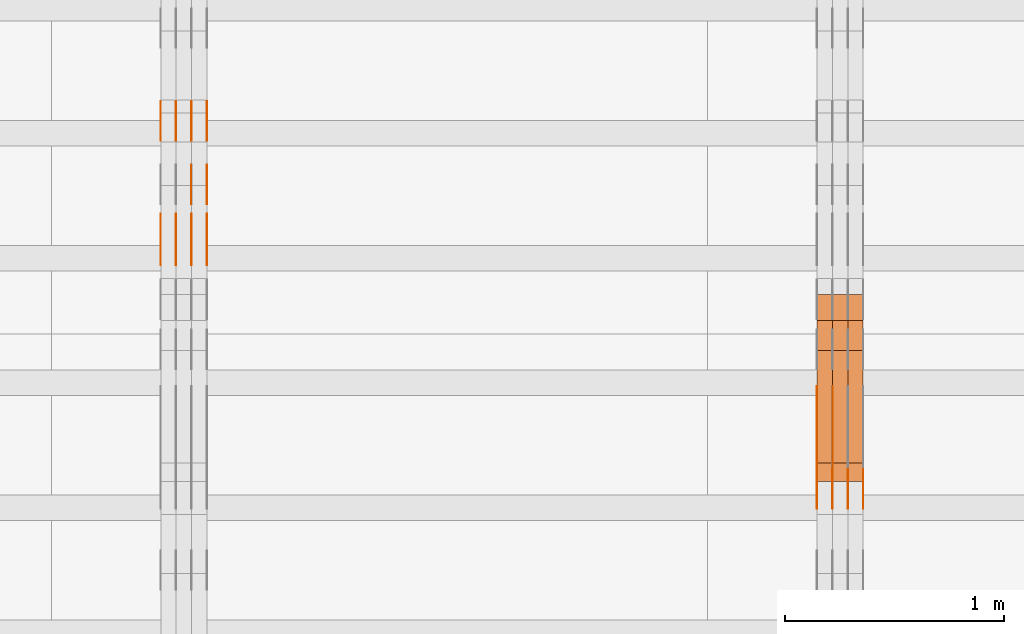
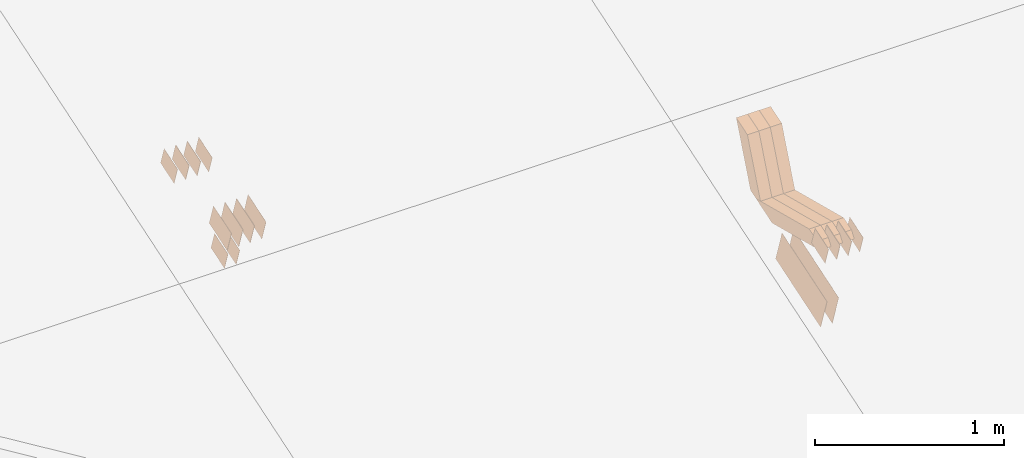
# One storey, part 70 of 385: 28 proxies.
"""IFC2X3 building model written with IfcOpenShell, lengths in millimetres."""

from ifc_helpers import new_model, entity, si_unit, converted_unit, derived_unit, direction, frame, origin, place, context, subcontext, project, spatial, polyline, outline, extrude, source, transform, mapped, material, type_object, type_shapes, element, save


model = new_model("IFC2X3")

# Units and contexts
model_context = context("Model", 3, precision=0.01, world=origin(), true_north=direction((6.12303176911189e-17, 1.0)))
body_context = subcontext(model_context, "Body", "Model", "MODEL_VIEW")
ifc_project = project(units=[si_unit("LENGTHUNIT", "METRE", prefix="MILLI"), si_unit("AREAUNIT", "SQUARE_METRE"), si_unit("VOLUMEUNIT", "CUBIC_METRE"), converted_unit("PLANEANGLEUNIT", "DEGREE", entity("IfcRatioMeasure", 0.0174532925199433), si_unit("PLANEANGLEUNIT", "RADIAN"), dimensions=[0, 0, 0, 0, 0, 0, 0]), si_unit("MASSUNIT", "GRAM", prefix="KILO"), derived_unit("MASSDENSITYUNIT", [(si_unit("MASSUNIT", "GRAM", prefix="KILO"), 1), (si_unit("LENGTHUNIT", "METRE"), -3)]), si_unit("TIMEUNIT", "SECOND"), si_unit("FREQUENCYUNIT", "HERTZ"), si_unit("THERMODYNAMICTEMPERATUREUNIT", "DEGREE_CELSIUS"), derived_unit("THERMALTRANSMITTANCEUNIT", [(si_unit("MASSUNIT", "GRAM", prefix="KILO"), 1), (si_unit("THERMODYNAMICTEMPERATUREUNIT", "KELVIN"), -1), (si_unit("TIMEUNIT", "SECOND"), -3)]), derived_unit("VOLUMETRICFLOWRATEUNIT", [(si_unit("LENGTHUNIT", "METRE"), 3), (si_unit("TIMEUNIT", "SECOND"), -1)]), si_unit("ELECTRICCURRENTUNIT", "AMPERE"), si_unit("ELECTRICVOLTAGEUNIT", "VOLT"), si_unit("POWERUNIT", "WATT"), si_unit("FORCEUNIT", "NEWTON", prefix="KILO"), si_unit("ILLUMINANCEUNIT", "LUX"), si_unit("LUMINOUSFLUXUNIT", "LUMEN"), si_unit("LUMINOUSINTENSITYUNIT", "CANDELA"), derived_unit("USERDEFINED", [(si_unit("MASSUNIT", "GRAM", prefix="KILO"), -1), (si_unit("LENGTHUNIT", "METRE"), -2), (si_unit("TIMEUNIT", "SECOND"), 3), (si_unit("LUMINOUSFLUXUNIT", "LUMEN"), 1)]), derived_unit("LINEARVELOCITYUNIT", [(si_unit("LENGTHUNIT", "METRE"), 1), (si_unit("TIMEUNIT", "SECOND"), -1)]), si_unit("PRESSUREUNIT", "PASCAL"), derived_unit("USERDEFINED", [(si_unit("LENGTHUNIT", "METRE"), -2), (si_unit("MASSUNIT", "GRAM", prefix="KILO"), 1), (si_unit("TIMEUNIT", "SECOND"), -2)])], contexts=[model_context])

# Site, building, storey
site_placement = place(None, origin())
site = spatial("IfcSite", under=ifc_project, at=site_placement, CompositionType="ELEMENT")
building_placement = place(site_placement, origin())
building = spatial("IfcBuilding", under=site, at=building_placement, CompositionType="ELEMENT")
storey_placement = place(building_placement, origin())
storey = spatial("IfcBuildingStorey", under=building, at=storey_placement, Name="Default", CompositionType="ELEMENT", Elevation=0.0)

# Proxies
ifc_material_1 = material(Name="IfcSurfaceStyle #211648")
building_element_proxy_type_1 = type_object("IfcBuildingElementProxyType", PredefinedType="NOTDEFINED", material=ifc_material_1)
shared_shape_1 = source(origin(), body_context, "Body", "SweptSolid", [
    extrude(outline(polyline([(-249.999749056184, -108.000229288163), (249.999396050782, -108.000229288163), (249.999749056184, 108.000229288163), (-249.999396050782, 108.000229288163), (-249.999749056184, -108.000229288163)])), frame((249.999841104007, 108.000229288163, 0.0), z_axis=(0.0, 0.0, 1.0), x_axis=(-1.0, 0.0, 0.0)), (0.0, 0.0, 1.0), 1.29999999999997),
])
type_shapes(building_element_proxy_type_1, [shared_shape_1])
proxy_1_placement = place(building_placement, frame((15246.3, 7917.13457673635, 1720.66532252899), z_axis=(-1.0, 0.0, 0.0), x_axis=(0.0, 0.951056516295124, 0.309016994375039)))
element("IfcBuildingElementProxy", 1, at=proxy_1_placement, inside=storey, type_object=building_element_proxy_type_1, material=ifc_material_1, context=body_context, shape_type="MappedRepresentation", body=[
    mapped(shared_shape_1, transform((0.0, 0.0, 0.0), scale=1.0)),
])
ifc_material_2 = material(Name="IfcSurfaceStyle #211591")
building_element_proxy_type_2 = type_object("IfcBuildingElementProxyType", PredefinedType="NOTDEFINED", material=ifc_material_2)
shared_shape_2 = source(origin(), body_context, "Body", "SweptSolid", [
    extrude(outline(polyline([(-249.999749056184, -108.000229288163), (249.999396050782, -108.000229288163), (249.999749056184, 108.000229288163), (-249.999396050782, 108.000229288163), (-249.999749056184, -108.000229288163)])), frame((249.999841104007, 108.000229288163, 0.0), z_axis=(0.0, 0.0, 1.0), x_axis=(-1.0, 0.0, 0.0)), (0.0, 0.0, 1.0), 1.29999999999997),
])
type_shapes(building_element_proxy_type_2, [shared_shape_2])
proxy_2_placement = place(building_placement, frame((15175.0, 7917.13457673635, 1720.66532252899), z_axis=(-1.0, 0.0, 0.0), x_axis=(0.0, 0.951056516295124, 0.309016994375039)))
element("IfcBuildingElementProxy", 2, at=proxy_2_placement, inside=storey, type_object=building_element_proxy_type_2, material=ifc_material_2, context=body_context, shape_type="MappedRepresentation", body=[
    mapped(shared_shape_2, transform((0.0, 0.0, 0.0), scale=1.0)),
])
ifc_material_3 = material(Name="IfcSurfaceStyle #198196")
building_element_proxy_type_3 = type_object("IfcBuildingElementProxyType", PredefinedType="NOTDEFINED", material=ifc_material_3)
shared_shape_3 = source(origin(), body_context, "Body", "SweptSolid", [
    extrude(outline(polyline([(-74.9998754286253, -60.0000016373506), (74.9998605591091, -60.0000016373506), (74.9998754286234, 60.0000016373506), (-74.9998605591072, 60.0000016373506), (-74.9998754286253, -60.0000016373506)])), frame((75.0007355357002, 60.0002637031812, 0.0), z_axis=(0.0, 0.0, 1.0), x_axis=(-1.0, 0.0, 0.0)), (0.0, 0.0, 1.0), 1.3),
])
type_shapes(building_element_proxy_type_3, [shared_shape_3])
proxy_3_placement = place(building_placement, frame((15386.3, 7899.79204652808, 2069.58672486412), z_axis=(-1.0, 0.0, 0.0), x_axis=(0.0, 0.951056516295154, 0.309016994374948)))
element("IfcBuildingElementProxy", 3, at=proxy_3_placement, inside=storey, type_object=building_element_proxy_type_3, material=ifc_material_3, context=body_context, shape_type="MappedRepresentation", body=[
    mapped(shared_shape_3, transform((0.0, 0.0, 0.0), scale=1.0)),
])
ifc_material_4 = material(Name="IfcSurfaceStyle #198139")
building_element_proxy_type_4 = type_object("IfcBuildingElementProxyType", PredefinedType="NOTDEFINED", material=ifc_material_4)
shared_shape_4 = source(origin(), body_context, "Body", "SweptSolid", [
    extrude(outline(polyline([(-74.9998754286253, -60.0000016373506), (74.9998605591091, -60.0000016373506), (74.9998754286234, 60.0000016373506), (-74.9998605591072, 60.0000016373506), (-74.9998754286253, -60.0000016373506)])), frame((75.0007355357002, 60.0002637031812, 0.0), z_axis=(0.0, 0.0, 1.0), x_axis=(-1.0, 0.0, 0.0)), (0.0, 0.0, 1.0), 1.3),
])
type_shapes(building_element_proxy_type_4, [shared_shape_4])
proxy_4_placement = place(building_placement, frame((15315.0, 7899.79204652808, 2069.58672486412), z_axis=(-1.0, 0.0, 0.0), x_axis=(0.0, 0.951056516295154, 0.309016994374948)))
element("IfcBuildingElementProxy", 4, at=proxy_4_placement, inside=storey, type_object=building_element_proxy_type_4, material=ifc_material_4, context=body_context, shape_type="MappedRepresentation", body=[
    mapped(shared_shape_4, transform((0.0, 0.0, 0.0), scale=1.0)),
])
ifc_material_5 = material(Name="IfcSurfaceStyle #198082")
building_element_proxy_type_5 = type_object("IfcBuildingElementProxyType", PredefinedType="NOTDEFINED", material=ifc_material_5)
shared_shape_5 = source(origin(), body_context, "Body", "SweptSolid", [
    extrude(outline(polyline([(-74.9998754286253, -60.0000016373506), (74.9998605591091, -60.0000016373506), (74.9998754286234, 60.0000016373506), (-74.9998605591072, 60.0000016373506), (-74.9998754286253, -60.0000016373506)])), frame((75.0007355357002, 60.0002637031812, 0.0), z_axis=(0.0, 0.0, 1.0), x_axis=(-1.0, 0.0, 0.0)), (0.0, 0.0, 1.0), 1.3),
])
type_shapes(building_element_proxy_type_5, [shared_shape_5])
proxy_5_placement = place(building_placement, frame((15316.3, 7899.79204652808, 2069.58672486412), z_axis=(-1.0, 0.0, 0.0), x_axis=(0.0, 0.951056516295154, 0.309016994374948)))
element("IfcBuildingElementProxy", 5, at=proxy_5_placement, inside=storey, type_object=building_element_proxy_type_5, material=ifc_material_5, context=body_context, shape_type="MappedRepresentation", body=[
    mapped(shared_shape_5, transform((0.0, 0.0, 0.0), scale=1.0)),
])
ifc_material_6 = material(Name="IfcSurfaceStyle #198025")
building_element_proxy_type_6 = type_object("IfcBuildingElementProxyType", PredefinedType="NOTDEFINED", material=ifc_material_6)
shared_shape_6 = source(origin(), body_context, "Body", "SweptSolid", [
    extrude(outline(polyline([(-74.9998754286253, -60.0000016373506), (74.9998605591091, -60.0000016373506), (74.9998754286234, 60.0000016373506), (-74.9998605591072, 60.0000016373506), (-74.9998754286253, -60.0000016373506)])), frame((75.0007355357002, 60.0002637031812, 0.0), z_axis=(0.0, 0.0, 1.0), x_axis=(-1.0, 0.0, 0.0)), (0.0, 0.0, 1.0), 1.29999999999999),
])
type_shapes(building_element_proxy_type_6, [shared_shape_6])
proxy_6_placement = place(building_placement, frame((15245.0, 7899.79204652808, 2069.58672486412), z_axis=(-1.0, 0.0, 0.0), x_axis=(0.0, 0.951056516295154, 0.309016994374948)))
element("IfcBuildingElementProxy", 6, at=proxy_6_placement, inside=storey, type_object=building_element_proxy_type_6, material=ifc_material_6, context=body_context, shape_type="MappedRepresentation", body=[
    mapped(shared_shape_6, transform((0.0, 0.0, 0.0), scale=1.0)),
])
ifc_material_7 = material(Name="IfcSurfaceStyle #197968")
building_element_proxy_type_7 = type_object("IfcBuildingElementProxyType", PredefinedType="NOTDEFINED", material=ifc_material_7)
shared_shape_7 = source(origin(), body_context, "Body", "SweptSolid", [
    extrude(outline(polyline([(-74.9998754286253, -60.0000016373506), (74.9998605591091, -60.0000016373506), (74.9998754286234, 60.0000016373506), (-74.9998605591072, 60.0000016373506), (-74.9998754286253, -60.0000016373506)])), frame((75.0007355357002, 60.0002637031812, 0.0), z_axis=(0.0, 0.0, 1.0), x_axis=(-1.0, 0.0, 0.0)), (0.0, 0.0, 1.0), 1.29999999999999),
])
type_shapes(building_element_proxy_type_7, [shared_shape_7])
proxy_7_placement = place(building_placement, frame((15246.3, 7899.79204652808, 2069.58672486412), z_axis=(-1.0, 0.0, 0.0), x_axis=(0.0, 0.951056516295154, 0.309016994374948)))
element("IfcBuildingElementProxy", 7, at=proxy_7_placement, inside=storey, type_object=building_element_proxy_type_7, material=ifc_material_7, context=body_context, shape_type="MappedRepresentation", body=[
    mapped(shared_shape_7, transform((0.0, 0.0, 0.0), scale=1.0)),
])
ifc_material_8 = material(Name="IfcSurfaceStyle #197911")
building_element_proxy_type_8 = type_object("IfcBuildingElementProxyType", PredefinedType="NOTDEFINED", material=ifc_material_8)
shared_shape_8 = source(origin(), body_context, "Body", "SweptSolid", [
    extrude(outline(polyline([(-74.9998754286253, -60.0000016373506), (74.9998605591091, -60.0000016373506), (74.9998754286234, 60.0000016373506), (-74.9998605591072, 60.0000016373506), (-74.9998754286253, -60.0000016373506)])), frame((75.0007355357002, 60.0002637031812, 0.0), z_axis=(0.0, 0.0, 1.0), x_axis=(-1.0, 0.0, 0.0)), (0.0, 0.0, 1.0), 1.29999999999999),
])
type_shapes(building_element_proxy_type_8, [shared_shape_8])
proxy_8_placement = place(building_placement, frame((15175.0, 7899.79204652808, 2069.58672486412), z_axis=(-1.0, 0.0, 0.0), x_axis=(0.0, 0.951056516295154, 0.309016994374948)))
element("IfcBuildingElementProxy", 8, at=proxy_8_placement, inside=storey, type_object=building_element_proxy_type_8, material=ifc_material_8, context=body_context, shape_type="MappedRepresentation", body=[
    mapped(shared_shape_8, transform((0.0, 0.0, 0.0), scale=1.0)),
])
ifc_material_9 = material(Name="IfcSurfaceStyle #185812")
building_element_proxy_type_9 = type_object("IfcBuildingElementProxyType", Name="T1-W45 185810", PredefinedType="NOTDEFINED", material=ifc_material_9)
shared_shape_9 = source(origin(), body_context, "Body", "SweptSolid", [
    extrude(outline(polyline([(-275.953018340717, -47.500197738425), (128.971267956636, -47.5001977384251), (168.669977842085, -0.000132525443043008), (174.867371111815, 47.5002640011466), (-196.55559856982, 47.5002640011466), (-275.953018340717, -47.500197738425)])), frame((174.867371111815, 47.5002640011466, 0.0), z_axis=(0.0, 0.0, 1.0), x_axis=(-1.0, 0.0, 0.0)), (0.0, 0.0, 1.0), 70.0),
])
type_shapes(building_element_proxy_type_9, [shared_shape_9])
proxy_9_placement = place(building_placement, frame((15385.0, 8621.494140625, 1941.33422851563), z_axis=(-1.0, 0.0, 0.0), x_axis=(0.0, 0.372787901688292, 0.927916580493549)))
element("IfcBuildingElementProxy", 9, at=proxy_9_placement, inside=storey, type_object=building_element_proxy_type_9, material=ifc_material_9, Name="T1-W45", context=body_context, shape_type="MappedRepresentation", body=[
    mapped(shared_shape_9, transform((0.0, 0.0, 0.0), scale=1.0)),
])
ifc_material_10 = material(Name="IfcSurfaceStyle #185746")
building_element_proxy_type_10 = type_object("IfcBuildingElementProxyType", Name="T1-W45 185744", PredefinedType="NOTDEFINED", material=ifc_material_10)
shared_shape_10 = source(origin(), body_context, "Body", "SweptSolid", [
    extrude(outline(polyline([(-275.953018340717, -47.500197738425), (128.971267956636, -47.5001977384251), (168.669977842085, -0.000132525443043008), (174.867371111815, 47.5002640011466), (-196.55559856982, 47.5002640011466), (-275.953018340717, -47.500197738425)])), frame((174.867371111815, 47.5002640011466, 0.0), z_axis=(0.0, 0.0, 1.0), x_axis=(-1.0, 0.0, 0.0)), (0.0, 0.0, 1.0), 70.0),
])
type_shapes(building_element_proxy_type_10, [shared_shape_10])
proxy_10_placement = place(building_placement, frame((15315.0, 8621.494140625, 1941.33422851563), z_axis=(-1.0, 0.0, 0.0), x_axis=(0.0, 0.372787901688292, 0.927916580493549)))
element("IfcBuildingElementProxy", 10, at=proxy_10_placement, inside=storey, type_object=building_element_proxy_type_10, material=ifc_material_10, Name="T1-W45", context=body_context, shape_type="MappedRepresentation", body=[
    mapped(shared_shape_10, transform((0.0, 0.0, 0.0), scale=1.0)),
])
ifc_material_11 = material(Name="IfcSurfaceStyle #185680")
building_element_proxy_type_11 = type_object("IfcBuildingElementProxyType", Name="T1-W45 185678", PredefinedType="NOTDEFINED", material=ifc_material_11)
shared_shape_11 = source(origin(), body_context, "Body", "SweptSolid", [
    extrude(outline(polyline([(-275.953018340717, -47.500197738425), (128.971267956636, -47.5001977384251), (168.669977842085, -0.000132525443043008), (174.867371111815, 47.5002640011466), (-196.55559856982, 47.5002640011466), (-275.953018340717, -47.500197738425)])), frame((174.867371111815, 47.5002640011466, 0.0), z_axis=(0.0, 0.0, 1.0), x_axis=(-1.0, 0.0, 0.0)), (0.0, 0.0, 1.0), 70.0),
])
type_shapes(building_element_proxy_type_11, [shared_shape_11])
proxy_11_placement = place(building_placement, frame((15245.0, 8621.494140625, 1941.33422851563), z_axis=(-1.0, 0.0, 0.0), x_axis=(0.0, 0.372787901688292, 0.927916580493549)))
element("IfcBuildingElementProxy", 11, at=proxy_11_placement, inside=storey, type_object=building_element_proxy_type_11, material=ifc_material_11, Name="T1-W45", context=body_context, shape_type="MappedRepresentation", body=[
    mapped(shared_shape_11, transform((0.0, 0.0, 0.0), scale=1.0)),
])
ifc_material_12 = material(Name="IfcSurfaceStyle #185416")
building_element_proxy_type_12 = type_object("IfcBuildingElementProxyType", Name="T1-W11 185414", PredefinedType="NOTDEFINED", material=ifc_material_12)
shared_shape_12 = source(origin(), body_context, "Body", "SweptSolid", [
    extrude(outline(polyline([(-261.366417792209, -47.5000378467523), (260.949520182121, -47.5000378467523), (242.928845159301, -7.41559889341215e-06), (168.237407166939, 47.5000415545517), (-410.749354716152, 47.5000415545517), (-261.366417792209, -47.5000378467523)])), frame((260.949520182121, 47.5000415545517, 0.0), z_axis=(0.0, 0.0, 1.0), x_axis=(-1.0, 0.0, 0.0)), (0.0, 0.0, 1.0), 70.0),
])
type_shapes(building_element_proxy_type_12, [shared_shape_12])
proxy_12_placement = place(building_placement, frame((15385.0, 8017.44318793234, 2097.03832883996), z_axis=(-1.0, 0.0, 0.0), x_axis=(0.0, 0.968347201599873, -0.249607085543851)))
element("IfcBuildingElementProxy", 12, at=proxy_12_placement, inside=storey, type_object=building_element_proxy_type_12, material=ifc_material_12, Name="T1-W11", context=body_context, shape_type="MappedRepresentation", body=[
    mapped(shared_shape_12, transform((0.0, 0.0, 0.0), scale=1.0)),
])
ifc_material_13 = material(Name="IfcSurfaceStyle #185350")
building_element_proxy_type_13 = type_object("IfcBuildingElementProxyType", Name="T1-W11 185348", PredefinedType="NOTDEFINED", material=ifc_material_13)
shared_shape_13 = source(origin(), body_context, "Body", "SweptSolid", [
    extrude(outline(polyline([(-261.366417792209, -47.5000378467523), (260.949520182121, -47.5000378467523), (242.928845159301, -7.41559889341215e-06), (168.237407166939, 47.5000415545517), (-410.749354716152, 47.5000415545517), (-261.366417792209, -47.5000378467523)])), frame((260.949520182121, 47.5000415545517, 0.0), z_axis=(0.0, 0.0, 1.0), x_axis=(-1.0, 0.0, 0.0)), (0.0, 0.0, 1.0), 70.0),
])
type_shapes(building_element_proxy_type_13, [shared_shape_13])
proxy_13_placement = place(building_placement, frame((15315.0, 8017.44318793234, 2097.03832883996), z_axis=(-1.0, 0.0, 0.0), x_axis=(0.0, 0.968347201599873, -0.249607085543851)))
element("IfcBuildingElementProxy", 13, at=proxy_13_placement, inside=storey, type_object=building_element_proxy_type_13, material=ifc_material_13, Name="T1-W11", context=body_context, shape_type="MappedRepresentation", body=[
    mapped(shared_shape_13, transform((0.0, 0.0, 0.0), scale=1.0)),
])
ifc_material_14 = material(Name="IfcSurfaceStyle #185284")
building_element_proxy_type_14 = type_object("IfcBuildingElementProxyType", Name="T1-W11 185282", PredefinedType="NOTDEFINED", material=ifc_material_14)
shared_shape_14 = source(origin(), body_context, "Body", "SweptSolid", [
    extrude(outline(polyline([(-261.366417792209, -47.5000378467523), (260.949520182121, -47.5000378467523), (242.928845159301, -7.41559889341215e-06), (168.237407166939, 47.5000415545517), (-410.749354716152, 47.5000415545517), (-261.366417792209, -47.5000378467523)])), frame((260.949520182121, 47.5000415545517, 0.0), z_axis=(0.0, 0.0, 1.0), x_axis=(-1.0, 0.0, 0.0)), (0.0, 0.0, 1.0), 70.0),
])
type_shapes(building_element_proxy_type_14, [shared_shape_14])
proxy_14_placement = place(building_placement, frame((15245.0, 8017.44318793234, 2097.03832883996), z_axis=(-1.0, 0.0, 0.0), x_axis=(0.0, 0.968347201599873, -0.249607085543851)))
element("IfcBuildingElementProxy", 14, at=proxy_14_placement, inside=storey, type_object=building_element_proxy_type_14, material=ifc_material_14, Name="T1-W11", context=body_context, shape_type="MappedRepresentation", body=[
    mapped(shared_shape_14, transform((0.0, 0.0, 0.0), scale=1.0)),
])
ifc_material_15 = material(Name="IfcSurfaceStyle #177102")
building_element_proxy_type_15 = type_object("IfcBuildingElementProxyType", PredefinedType="NOTDEFINED", material=ifc_material_15)
shared_shape_15 = source(origin(), body_context, "Body", "SweptSolid", [
    extrude(outline(polyline([(-99.999644645517, -72.0000317581407), (100.000028485991, -72.0000317581407), (99.999644645517, 72.0000317581407), (-100.000028485991, 72.0000317581407), (-99.999644645517, -72.0000317581407)])), frame((100.000028485991, 72.0000317581407, 0.0), z_axis=(0.0, 0.0, 1.0), x_axis=(-1.0, 0.0, 0.0)), (0.0, 0.0, 1.0), 1.3),
])
type_shapes(building_element_proxy_type_15, [shared_shape_15])
proxy_15_placement = place(building_placement, frame((12386.3, 9012.6304394324, 2546.30522609783), z_axis=(-1.0, 0.0, 0.0), x_axis=(0.0, 0.951056516295154, 0.309016994374948)))
element("IfcBuildingElementProxy", 15, at=proxy_15_placement, inside=storey, type_object=building_element_proxy_type_15, material=ifc_material_15, context=body_context, shape_type="MappedRepresentation", body=[
    mapped(shared_shape_15, transform((0.0, 0.0, 0.0), scale=1.0)),
])
ifc_material_16 = material(Name="IfcSurfaceStyle #177045")
building_element_proxy_type_16 = type_object("IfcBuildingElementProxyType", PredefinedType="NOTDEFINED", material=ifc_material_16)
shared_shape_16 = source(origin(), body_context, "Body", "SweptSolid", [
    extrude(outline(polyline([(-99.999644645517, -72.0000317581407), (100.000028485991, -72.0000317581407), (99.999644645517, 72.0000317581407), (-100.000028485991, 72.0000317581407), (-99.999644645517, -72.0000317581407)])), frame((100.000028485991, 72.0000317581407, 0.0), z_axis=(0.0, 0.0, 1.0), x_axis=(-1.0, 0.0, 0.0)), (0.0, 0.0, 1.0), 1.3),
])
type_shapes(building_element_proxy_type_16, [shared_shape_16])
proxy_16_placement = place(building_placement, frame((12315.0, 9012.6304394324, 2546.30522609783), z_axis=(-1.0, 0.0, 0.0), x_axis=(0.0, 0.951056516295154, 0.309016994374948)))
element("IfcBuildingElementProxy", 16, at=proxy_16_placement, inside=storey, type_object=building_element_proxy_type_16, material=ifc_material_16, context=body_context, shape_type="MappedRepresentation", body=[
    mapped(shared_shape_16, transform((0.0, 0.0, 0.0), scale=1.0)),
])
ifc_material_17 = material(Name="IfcSurfaceStyle #176988")
building_element_proxy_type_17 = type_object("IfcBuildingElementProxyType", PredefinedType="NOTDEFINED", material=ifc_material_17)
shared_shape_17 = source(origin(), body_context, "Body", "SweptSolid", [
    extrude(outline(polyline([(-99.999644645517, -72.0000317581407), (100.000028485991, -72.0000317581407), (99.999644645517, 72.0000317581407), (-100.000028485991, 72.0000317581407), (-99.999644645517, -72.0000317581407)])), frame((100.000028485991, 72.0000317581407, 0.0), z_axis=(0.0, 0.0, 1.0), x_axis=(-1.0, 0.0, 0.0)), (0.0, 0.0, 1.0), 1.3),
])
type_shapes(building_element_proxy_type_17, [shared_shape_17])
proxy_17_placement = place(building_placement, frame((12316.3, 9012.6304394324, 2546.30522609783), z_axis=(-1.0, 0.0, 0.0), x_axis=(0.0, 0.951056516295154, 0.309016994374948)))
element("IfcBuildingElementProxy", 17, at=proxy_17_placement, inside=storey, type_object=building_element_proxy_type_17, material=ifc_material_17, context=body_context, shape_type="MappedRepresentation", body=[
    mapped(shared_shape_17, transform((0.0, 0.0, 0.0), scale=1.0)),
])
ifc_material_18 = material(Name="IfcSurfaceStyle #176931")
building_element_proxy_type_18 = type_object("IfcBuildingElementProxyType", PredefinedType="NOTDEFINED", material=ifc_material_18)
shared_shape_18 = source(origin(), body_context, "Body", "SweptSolid", [
    extrude(outline(polyline([(-99.999644645517, -72.0000317581407), (100.000028485991, -72.0000317581407), (99.999644645517, 72.0000317581407), (-100.000028485991, 72.0000317581407), (-99.999644645517, -72.0000317581407)])), frame((100.000028485991, 72.0000317581407, 0.0), z_axis=(0.0, 0.0, 1.0), x_axis=(-1.0, 0.0, 0.0)), (0.0, 0.0, 1.0), 1.29999999999998),
])
type_shapes(building_element_proxy_type_18, [shared_shape_18])
proxy_18_placement = place(building_placement, frame((12245.0, 9012.6304394324, 2546.30522609783), z_axis=(-1.0, 0.0, 0.0), x_axis=(0.0, 0.951056516295154, 0.309016994374948)))
element("IfcBuildingElementProxy", 18, at=proxy_18_placement, inside=storey, type_object=building_element_proxy_type_18, material=ifc_material_18, context=body_context, shape_type="MappedRepresentation", body=[
    mapped(shared_shape_18, transform((0.0, 0.0, 0.0), scale=1.0)),
])
ifc_material_19 = material(Name="IfcSurfaceStyle #176874")
building_element_proxy_type_19 = type_object("IfcBuildingElementProxyType", PredefinedType="NOTDEFINED", material=ifc_material_19)
shared_shape_19 = source(origin(), body_context, "Body", "SweptSolid", [
    extrude(outline(polyline([(-99.999644645517, -72.0000317581407), (100.000028485991, -72.0000317581407), (99.999644645517, 72.0000317581407), (-100.000028485991, 72.0000317581407), (-99.999644645517, -72.0000317581407)])), frame((100.000028485991, 72.0000317581407, 0.0), z_axis=(0.0, 0.0, 1.0), x_axis=(-1.0, 0.0, 0.0)), (0.0, 0.0, 1.0), 1.29999999999998),
])
type_shapes(building_element_proxy_type_19, [shared_shape_19])
proxy_19_placement = place(building_placement, frame((12246.3, 9012.6304394324, 2546.30522609783), z_axis=(-1.0, 0.0, 0.0), x_axis=(0.0, 0.951056516295154, 0.309016994374948)))
element("IfcBuildingElementProxy", 19, at=proxy_19_placement, inside=storey, type_object=building_element_proxy_type_19, material=ifc_material_19, context=body_context, shape_type="MappedRepresentation", body=[
    mapped(shared_shape_19, transform((0.0, 0.0, 0.0), scale=1.0)),
])
ifc_material_20 = material(Name="IfcSurfaceStyle #176817")
building_element_proxy_type_20 = type_object("IfcBuildingElementProxyType", PredefinedType="NOTDEFINED", material=ifc_material_20)
shared_shape_20 = source(origin(), body_context, "Body", "SweptSolid", [
    extrude(outline(polyline([(-99.999644645517, -72.0000317581407), (100.000028485991, -72.0000317581407), (99.999644645517, 72.0000317581407), (-100.000028485991, 72.0000317581407), (-99.999644645517, -72.0000317581407)])), frame((100.000028485991, 72.0000317581407, 0.0), z_axis=(0.0, 0.0, 1.0), x_axis=(-1.0, 0.0, 0.0)), (0.0, 0.0, 1.0), 1.29999999999999),
])
type_shapes(building_element_proxy_type_20, [shared_shape_20])
proxy_20_placement = place(building_placement, frame((12175.0, 9012.6304394324, 2546.30522609783), z_axis=(-1.0, 0.0, 0.0), x_axis=(0.0, 0.951056516295154, 0.309016994374948)))
element("IfcBuildingElementProxy", 20, at=proxy_20_placement, inside=storey, type_object=building_element_proxy_type_20, material=ifc_material_20, context=body_context, shape_type="MappedRepresentation", body=[
    mapped(shared_shape_20, transform((0.0, 0.0, 0.0), scale=1.0)),
])
ifc_material_21 = material(Name="IfcSurfaceStyle #176760")
building_element_proxy_type_21 = type_object("IfcBuildingElementProxyType", PredefinedType="NOTDEFINED", material=ifc_material_21)
shared_shape_21 = source(origin(), body_context, "Body", "SweptSolid", [
    extrude(outline(polyline([(-74.9998754286207, -60.0000016373506), (74.9998605591063, -60.0000016373506), (74.9998754286244, 60.0000016373506), (-74.9998605591099, 60.0000016373506), (-74.9998754286207, -60.0000016373506)])), frame((74.9998754286244, 60.0000016373506, 0.0), z_axis=(0.0, 0.0, 1.0), x_axis=(-1.0, 0.0, 0.0)), (0.0, 0.0, 1.0), 1.3),
])
type_shapes(building_element_proxy_type_21, [shared_shape_21])
proxy_21_placement = place(building_placement, frame((12386.3, 9580.89841427132, 2615.81135078741), z_axis=(-1.0, 0.0, 0.0), x_axis=(0.0, 0.951056516295154, 0.309016994374948)))
element("IfcBuildingElementProxy", 21, at=proxy_21_placement, inside=storey, type_object=building_element_proxy_type_21, material=ifc_material_21, context=body_context, shape_type="MappedRepresentation", body=[
    mapped(shared_shape_21, transform((0.0, 0.0, 0.0), scale=1.0)),
])
ifc_material_22 = material(Name="IfcSurfaceStyle #176703")
building_element_proxy_type_22 = type_object("IfcBuildingElementProxyType", PredefinedType="NOTDEFINED", material=ifc_material_22)
shared_shape_22 = source(origin(), body_context, "Body", "SweptSolid", [
    extrude(outline(polyline([(-74.9998754286207, -60.0000016373506), (74.9998605591063, -60.0000016373506), (74.9998754286244, 60.0000016373506), (-74.9998605591099, 60.0000016373506), (-74.9998754286207, -60.0000016373506)])), frame((74.9998754286244, 60.0000016373506, 0.0), z_axis=(0.0, 0.0, 1.0), x_axis=(-1.0, 0.0, 0.0)), (0.0, 0.0, 1.0), 1.3),
])
type_shapes(building_element_proxy_type_22, [shared_shape_22])
proxy_22_placement = place(building_placement, frame((12315.0, 9580.89841427132, 2615.81135078741), z_axis=(-1.0, 0.0, 0.0), x_axis=(0.0, 0.951056516295154, 0.309016994374948)))
element("IfcBuildingElementProxy", 22, at=proxy_22_placement, inside=storey, type_object=building_element_proxy_type_22, material=ifc_material_22, context=body_context, shape_type="MappedRepresentation", body=[
    mapped(shared_shape_22, transform((0.0, 0.0, 0.0), scale=1.0)),
])
ifc_material_23 = material(Name="IfcSurfaceStyle #176646")
building_element_proxy_type_23 = type_object("IfcBuildingElementProxyType", PredefinedType="NOTDEFINED", material=ifc_material_23)
shared_shape_23 = source(origin(), body_context, "Body", "SweptSolid", [
    extrude(outline(polyline([(-74.9998754286207, -60.0000016373506), (74.9998605591063, -60.0000016373506), (74.9998754286244, 60.0000016373506), (-74.9998605591099, 60.0000016373506), (-74.9998754286207, -60.0000016373506)])), frame((74.9998754286244, 60.0000016373506, 0.0), z_axis=(0.0, 0.0, 1.0), x_axis=(-1.0, 0.0, 0.0)), (0.0, 0.0, 1.0), 1.3),
])
type_shapes(building_element_proxy_type_23, [shared_shape_23])
proxy_23_placement = place(building_placement, frame((12316.3, 9580.89841427132, 2615.81135078741), z_axis=(-1.0, 0.0, 0.0), x_axis=(0.0, 0.951056516295154, 0.309016994374948)))
element("IfcBuildingElementProxy", 23, at=proxy_23_placement, inside=storey, type_object=building_element_proxy_type_23, material=ifc_material_23, context=body_context, shape_type="MappedRepresentation", body=[
    mapped(shared_shape_23, transform((0.0, 0.0, 0.0), scale=1.0)),
])
ifc_material_24 = material(Name="IfcSurfaceStyle #176589")
building_element_proxy_type_24 = type_object("IfcBuildingElementProxyType", PredefinedType="NOTDEFINED", material=ifc_material_24)
shared_shape_24 = source(origin(), body_context, "Body", "SweptSolid", [
    extrude(outline(polyline([(-74.9998754286207, -60.0000016373506), (74.9998605591063, -60.0000016373506), (74.9998754286244, 60.0000016373506), (-74.9998605591099, 60.0000016373506), (-74.9998754286207, -60.0000016373506)])), frame((74.9998754286244, 60.0000016373506, 0.0), z_axis=(0.0, 0.0, 1.0), x_axis=(-1.0, 0.0, 0.0)), (0.0, 0.0, 1.0), 1.29999999999999),
])
type_shapes(building_element_proxy_type_24, [shared_shape_24])
proxy_24_placement = place(building_placement, frame((12245.0, 9580.89841427132, 2615.81135078741), z_axis=(-1.0, 0.0, 0.0), x_axis=(0.0, 0.951056516295154, 0.309016994374948)))
element("IfcBuildingElementProxy", 24, at=proxy_24_placement, inside=storey, type_object=building_element_proxy_type_24, material=ifc_material_24, context=body_context, shape_type="MappedRepresentation", body=[
    mapped(shared_shape_24, transform((0.0, 0.0, 0.0), scale=1.0)),
])
ifc_material_25 = material(Name="IfcSurfaceStyle #176532")
building_element_proxy_type_25 = type_object("IfcBuildingElementProxyType", PredefinedType="NOTDEFINED", material=ifc_material_25)
shared_shape_25 = source(origin(), body_context, "Body", "SweptSolid", [
    extrude(outline(polyline([(-74.9998754286207, -60.0000016373506), (74.9998605591063, -60.0000016373506), (74.9998754286244, 60.0000016373506), (-74.9998605591099, 60.0000016373506), (-74.9998754286207, -60.0000016373506)])), frame((74.9998754286244, 60.0000016373506, 0.0), z_axis=(0.0, 0.0, 1.0), x_axis=(-1.0, 0.0, 0.0)), (0.0, 0.0, 1.0), 1.29999999999999),
])
type_shapes(building_element_proxy_type_25, [shared_shape_25])
proxy_25_placement = place(building_placement, frame((12246.3, 9580.89841427132, 2615.81135078741), z_axis=(-1.0, 0.0, 0.0), x_axis=(0.0, 0.951056516295154, 0.309016994374948)))
element("IfcBuildingElementProxy", 25, at=proxy_25_placement, inside=storey, type_object=building_element_proxy_type_25, material=ifc_material_25, context=body_context, shape_type="MappedRepresentation", body=[
    mapped(shared_shape_25, transform((0.0, 0.0, 0.0), scale=1.0)),
])
ifc_material_26 = material(Name="IfcSurfaceStyle #176475")
building_element_proxy_type_26 = type_object("IfcBuildingElementProxyType", PredefinedType="NOTDEFINED", material=ifc_material_26)
shared_shape_26 = source(origin(), body_context, "Body", "SweptSolid", [
    extrude(outline(polyline([(-74.9998754286207, -60.0000016373506), (74.9998605591063, -60.0000016373506), (74.9998754286244, 60.0000016373506), (-74.9998605591099, 60.0000016373506), (-74.9998754286207, -60.0000016373506)])), frame((74.9998754286244, 60.0000016373506, 0.0), z_axis=(0.0, 0.0, 1.0), x_axis=(-1.0, 0.0, 0.0)), (0.0, 0.0, 1.0), 1.29999999999999),
])
type_shapes(building_element_proxy_type_26, [shared_shape_26])
proxy_26_placement = place(building_placement, frame((12175.0, 9580.89841427132, 2615.81135078741), z_axis=(-1.0, 0.0, 0.0), x_axis=(0.0, 0.951056516295154, 0.309016994374948)))
element("IfcBuildingElementProxy", 26, at=proxy_26_placement, inside=storey, type_object=building_element_proxy_type_26, material=ifc_material_26, context=body_context, shape_type="MappedRepresentation", body=[
    mapped(shared_shape_26, transform((0.0, 0.0, 0.0), scale=1.0)),
])
ifc_material_27 = material(Name="IfcSurfaceStyle #175734")
building_element_proxy_type_27 = type_object("IfcBuildingElementProxyType", PredefinedType="NOTDEFINED", material=ifc_material_27)
shared_shape_27 = source(origin(), body_context, "Body", "SweptSolid", [
    extrude(outline(polyline([(-75.0008041947458, -59.9996998629349), (75.0007893252423, -59.9996998629349), (75.0008041947458, 59.9996998629349), (-75.0007893252423, 59.9996998629349), (-75.0008041947458, -59.9996998629349)])), frame((75.0008041947458, 60.0002282421692, 0.0), z_axis=(0.0, 0.0, 1.0), x_axis=(-1.0, 0.0, 0.0)), (0.0, 0.0, 1.0), 1.3),
])
type_shapes(building_element_proxy_type_27, [shared_shape_27])
proxy_27_placement = place(building_placement, frame((12386.3, 9291.048828125, 2194.94482421875), z_axis=(-1.0, 0.0, 0.0), x_axis=(0.0, 0.951056516295124, 0.309016994375039)))
element("IfcBuildingElementProxy", 27, at=proxy_27_placement, inside=storey, type_object=building_element_proxy_type_27, material=ifc_material_27, context=body_context, shape_type="MappedRepresentation", body=[
    mapped(shared_shape_27, transform((0.0, 0.0, 0.0), scale=1.0)),
])
ifc_material_28 = material(Name="IfcSurfaceStyle #175677")
building_element_proxy_type_28 = type_object("IfcBuildingElementProxyType", PredefinedType="NOTDEFINED", material=ifc_material_28)
shared_shape_28 = source(origin(), body_context, "Body", "SweptSolid", [
    extrude(outline(polyline([(-75.0008041947458, -59.9996998629349), (75.0007893252423, -59.9996998629349), (75.0008041947458, 59.9996998629349), (-75.0007893252423, 59.9996998629349), (-75.0008041947458, -59.9996998629349)])), frame((75.0008041947458, 60.0002282421692, 0.0), z_axis=(0.0, 0.0, 1.0), x_axis=(-1.0, 0.0, 0.0)), (0.0, 0.0, 1.0), 1.3),
])
type_shapes(building_element_proxy_type_28, [shared_shape_28])
proxy_28_placement = place(building_placement, frame((12315.0, 9291.048828125, 2194.94482421875), z_axis=(-1.0, 0.0, 0.0), x_axis=(0.0, 0.951056516295124, 0.309016994375039)))
element("IfcBuildingElementProxy", 28, at=proxy_28_placement, inside=storey, type_object=building_element_proxy_type_28, material=ifc_material_28, context=body_context, shape_type="MappedRepresentation", body=[
    mapped(shared_shape_28, transform((0.0, 0.0, 0.0), scale=1.0)),
])

save(model, "model.ifc")
